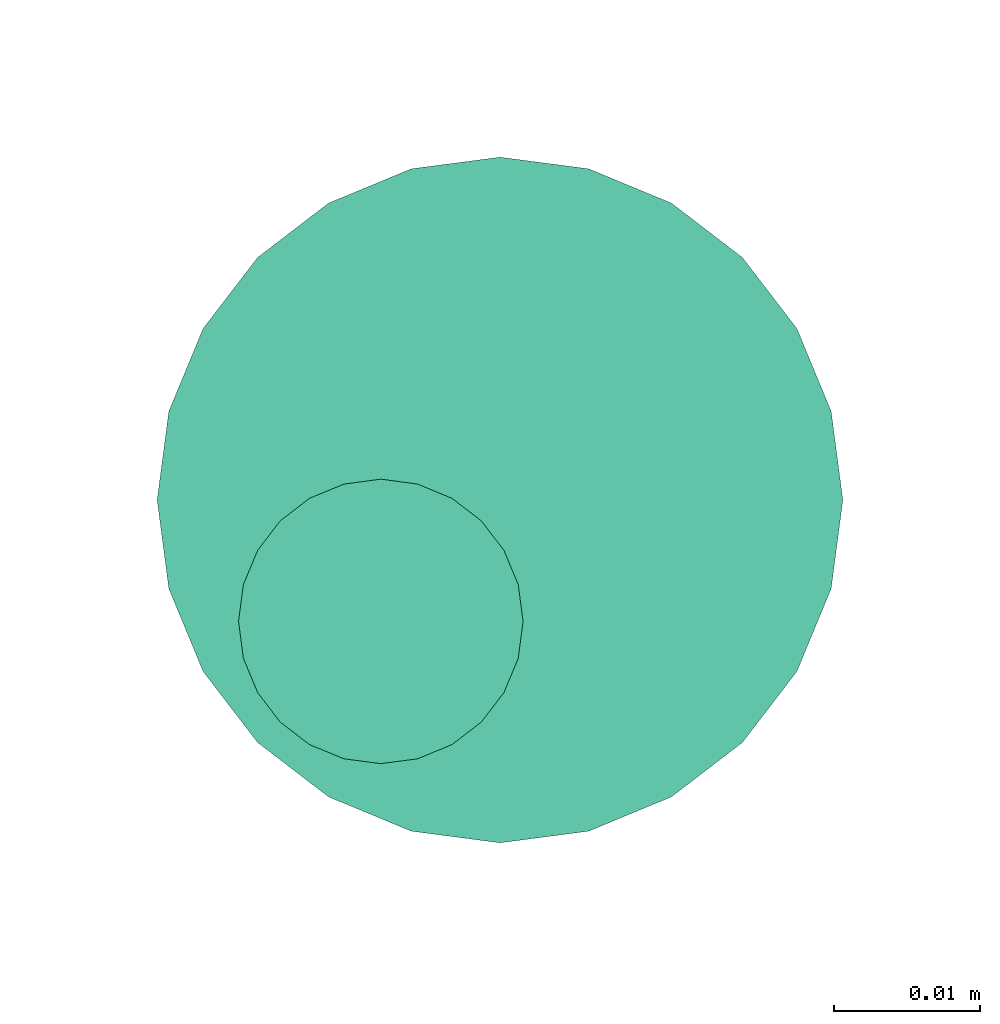
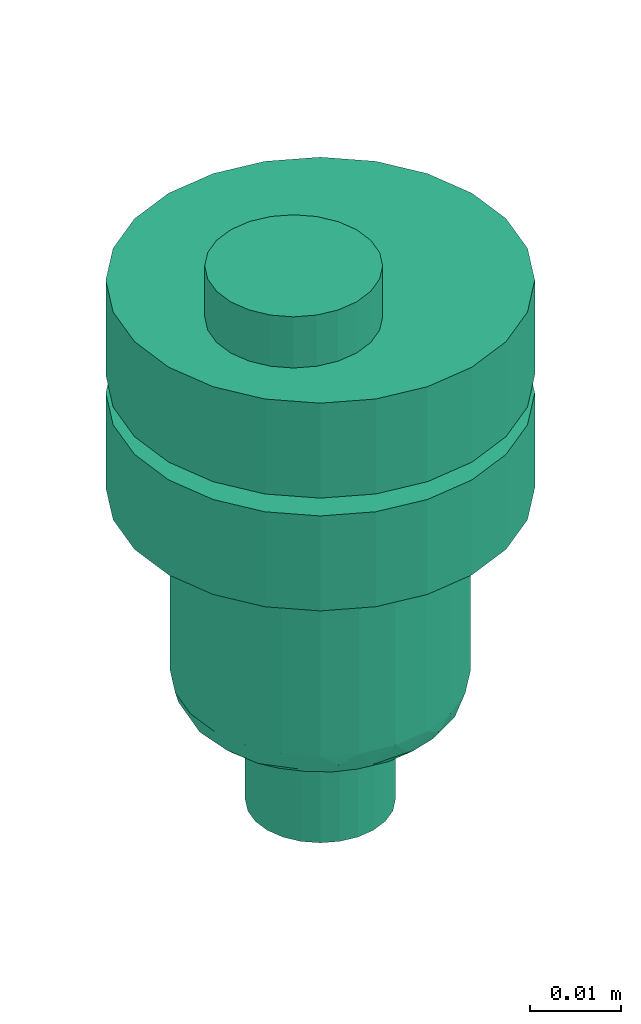
# One storey, part 64 of 93: 1 flow controller.
"""IFC2X3 building model written with IfcOpenShell, lengths in millimetres."""

from ifc_helpers import new_model, entity, si_unit, converted_unit, derived_unit, direction, frame, origin, place, context, subcontext, project, spatial, faceted_brep, source, transform, mapped, material, type_object, type_shapes, element, save


model = new_model("IFC2X3")

# Units and contexts
model_context = context("Model", 3, precision=0.01, world=origin(), true_north=direction((6.12303176911189e-17, 1.0)))
body_context = subcontext(model_context, "Body", "Model", "MODEL_VIEW")
ifc_project = project(units=[si_unit("LENGTHUNIT", "METRE", prefix="MILLI"), si_unit("AREAUNIT", "SQUARE_METRE"), si_unit("VOLUMEUNIT", "CUBIC_METRE"), converted_unit("PLANEANGLEUNIT", "DEGREE", entity("IfcRatioMeasure", 0.0174532925199433), si_unit("PLANEANGLEUNIT", "RADIAN"), dimensions=[0, 0, 0, 0, 0, 0, 0]), si_unit("MASSUNIT", "GRAM", prefix="KILO"), derived_unit("MASSDENSITYUNIT", [(si_unit("MASSUNIT", "GRAM", prefix="KILO"), 1), (si_unit("LENGTHUNIT", "METRE"), -3)]), derived_unit("MOMENTOFINERTIAUNIT", [(si_unit("LENGTHUNIT", "METRE"), 4)]), si_unit("TIMEUNIT", "SECOND"), si_unit("FREQUENCYUNIT", "HERTZ"), si_unit("THERMODYNAMICTEMPERATUREUNIT", "DEGREE_CELSIUS"), derived_unit("THERMALTRANSMITTANCEUNIT", [(si_unit("MASSUNIT", "GRAM", prefix="KILO"), 1), (si_unit("THERMODYNAMICTEMPERATUREUNIT", "KELVIN"), -1), (si_unit("TIMEUNIT", "SECOND"), -3)]), derived_unit("VOLUMETRICFLOWRATEUNIT", [(si_unit("LENGTHUNIT", "METRE"), 3), (si_unit("TIMEUNIT", "SECOND"), -1)]), derived_unit("MASSFLOWRATEUNIT", [(si_unit("MASSUNIT", "GRAM", prefix="KILO"), 1), (si_unit("TIMEUNIT", "SECOND"), -1)]), derived_unit("ROTATIONALFREQUENCYUNIT", [(si_unit("TIMEUNIT", "SECOND"), -1)]), si_unit("ELECTRICCURRENTUNIT", "AMPERE"), si_unit("ELECTRICVOLTAGEUNIT", "VOLT"), si_unit("POWERUNIT", "WATT"), si_unit("FORCEUNIT", "NEWTON", prefix="KILO"), si_unit("ILLUMINANCEUNIT", "LUX"), si_unit("LUMINOUSFLUXUNIT", "LUMEN"), si_unit("LUMINOUSINTENSITYUNIT", "CANDELA"), derived_unit("USERDEFINED", [(si_unit("MASSUNIT", "GRAM", prefix="KILO"), -1), (si_unit("LENGTHUNIT", "METRE"), -2), (si_unit("TIMEUNIT", "SECOND"), 3), (si_unit("LUMINOUSFLUXUNIT", "LUMEN"), 1)]), derived_unit("LINEARVELOCITYUNIT", [(si_unit("LENGTHUNIT", "METRE"), 1), (si_unit("TIMEUNIT", "SECOND"), -1)]), si_unit("PRESSUREUNIT", "PASCAL"), derived_unit("USERDEFINED", [(si_unit("LENGTHUNIT", "METRE"), -2), (si_unit("MASSUNIT", "GRAM", prefix="KILO"), 1), (si_unit("TIMEUNIT", "SECOND"), -2)]), derived_unit("LINEARFORCEUNIT", [(si_unit("MASSUNIT", "GRAM", prefix="KILO"), 1), (si_unit("LENGTHUNIT", "METRE"), 1), (si_unit("TIMEUNIT", "SECOND"), -2), (si_unit("LENGTHUNIT", "METRE"), -1)]), derived_unit("PLANARFORCEUNIT", [(si_unit("MASSUNIT", "GRAM", prefix="KILO"), 1), (si_unit("LENGTHUNIT", "METRE"), 1), (si_unit("TIMEUNIT", "SECOND"), -2), (si_unit("LENGTHUNIT", "METRE"), -2)])], contexts=[model_context])

# Site, building, storey
site_placement = place(None, origin())
site = spatial("IfcSite", under=ifc_project, at=site_placement, CompositionType="ELEMENT")
building_placement = place(site_placement, origin())
building = spatial("IfcBuilding", under=site, at=building_placement, CompositionType="ELEMENT")
storey_placement = place(building_placement, frame((0.0, 0.0, -4200.0)))
storey = spatial("IfcBuildingStorey", under=building, at=storey_placement, CompositionType="ELEMENT", Elevation=-4200.0)

# Flow controller
ifc_material = material()
valve_type = type_object("IfcValveType", PredefinedType="NOTDEFINED", material=ifc_material)
shared_shape = source(origin(), body_context, "Body", "Brep", [
    faceted_brep([(-6.86, -13.27, -15.58), (-5.66, -12.77, -15.58), (-5.66, -12.77, -13.2), (-6.86, -13.27, -13.2), (-6.86, -13.27, -0.5), (-5.66, -12.77, -0.5), (-5.66, -12.77, 2.49), (-6.86, -13.27, 2.49), (-8.16, -13.44, -15.58), (-8.16, -13.44, -13.2), (-8.16, -13.44, -0.5), (-8.16, -13.44, 2.49), (-3.83, -10.94, -15.58), (-3.33, -9.74, -15.58), (-3.33, -9.74, -13.2), (-3.83, -10.94, -13.2), (-3.83, -10.94, -0.5), (-3.33, -9.74, -0.5), (-3.33, -9.74, 2.49), (-3.83, -10.94, 2.49), (-4.62, -11.98, -15.58), (-4.62, -11.98, -13.2), (-4.62, -11.98, -0.5), (-4.62, -11.98, 2.49), (-3.16, -8.44, -13.2), (-3.16, -8.44, -15.58), (-3.16, -8.44, 2.49), (-3.16, -8.44, -0.5), (-3.83, -5.94, -15.58), (-4.62, -4.91, -15.58), (-4.62, -4.91, -13.2), (-3.83, -5.94, -13.2), (-3.83, -5.94, -0.5), (-4.62, -4.91, -0.5), (-4.62, -4.91, 2.49), (-3.83, -5.94, 2.49), (-3.33, -7.15, -15.58), (-3.33, -7.15, -13.2), (-3.33, -7.15, -0.5), (-3.33, -7.15, 2.49), (-6.86, -3.61, -15.58), (-8.16, -3.44, -15.58), (-8.16, -3.44, -13.2), (-6.86, -3.61, -13.2), (-6.86, -3.61, -0.5), (-8.16, -3.44, -0.5), (-8.16, -3.44, 2.49), (-6.86, -3.61, 2.49), (-5.66, -4.11, -15.58), (-5.66, -4.11, -13.2), (-5.66, -4.11, -0.5), (-5.66, -4.11, 2.49), (-9.45, -3.61, -0.5), (-9.45, -3.61, 2.49), (-9.45, -3.61, -15.58), (-9.45, -3.61, -13.2), (-10.66, -4.11, -0.5), (-10.66, -4.11, 2.49), (-10.66, -4.11, -15.58), (-10.66, -4.11, -13.2), (-12.49, -5.94, 2.49), (-11.69, -4.91, 2.49), (-11.69, -4.91, -0.5), (-12.49, -5.94, -0.5), (-11.69, -4.91, -15.58), (-12.49, -5.94, -15.58), (-12.49, -5.94, -13.2), (-11.69, -4.91, -13.2), (-12.99, -7.15, 2.49), (-12.99, -7.15, -0.5), (-12.99, -7.15, -15.58), (-12.99, -7.15, -13.2), (-13.16, -8.44, 2.49), (-13.16, -8.44, -0.5), (-13.16, -8.44, -13.2), (-13.16, -8.44, -15.58), (-12.49, -10.94, -0.5), (-12.49, -10.94, 2.49), (-12.99, -9.74, 2.49), (-12.99, -9.74, -0.5), (-12.99, -9.74, -15.58), (-12.49, -10.94, -15.58), (-12.49, -10.94, -13.2), (-12.99, -9.74, -13.2), (-11.69, -11.98, -0.5), (-11.69, -11.98, 2.49), (-11.69, -11.98, -15.58), (-11.69, -11.98, -13.2), (-9.45, -13.27, 2.49), (-10.66, -12.77, 2.49), (-10.66, -12.77, -0.5), (-9.45, -13.27, -0.5), (-10.66, -12.77, -15.58), (-9.45, -13.27, -15.58), (-9.45, -13.27, -13.2), (-10.66, -12.77, -13.2), (6.08, -22.7, -0.5), (0.0, -23.5, -0.5), (11.75, -20.35, -0.5), (16.62, -16.62, -0.5), (20.35, -11.75, -0.5), (22.7, -6.08, -0.5), (23.5, 0.0, -0.5), (22.7, 6.08, -0.5), (20.35, 11.75, -0.5), (16.62, 16.62, -0.5), (11.75, 20.35, -0.5), (6.08, 22.7, -0.5), (0.0, 23.5, -0.5), (-6.08, 22.7, -0.5), (-11.75, 20.35, -0.5), (-16.62, 16.62, -0.5), (-20.35, 11.75, -0.5), (-22.7, 6.08, -0.5), (-23.5, 0.0, -0.5), (-22.7, -6.08, -0.5), (-20.35, -11.75, -0.5), (-16.62, -16.62, -0.5), (-11.75, -20.35, -0.5), (-6.08, -22.7, -0.5), (11.75, 20.35, -13.2), (6.08, 22.7, -13.2), (16.62, 16.62, -13.2), (20.35, 11.75, -13.2), (22.7, 6.08, -13.2), (23.5, 0.0, -13.2), (22.7, -6.08, -13.2), (20.35, -11.75, -13.2), (16.62, -16.62, -13.2), (11.75, -20.35, -13.2), (6.08, -22.7, -13.2), (0.0, -23.5, -13.2), (-6.08, -22.7, -13.2), (-11.75, -20.35, -13.2), (-16.62, -16.62, -13.2), (-20.35, -11.75, -13.2), (-22.7, -6.08, -13.2), (-23.5, 0.0, -13.2), (-22.7, 6.08, -13.2), (-20.35, 11.75, -13.2), (-16.62, 16.62, -13.2), (-11.75, 20.35, -13.2), (-6.08, 22.7, -13.2), (0.0, 23.5, -13.2), (-22.7, -6.08, -28.28), (-22.7, -6.08, -15.58), (-23.5, 0.0, -15.58), (-23.5, 0.0, -28.28), (-20.35, -11.75, -28.28), (-20.35, -11.75, -15.58), (-11.75, -20.35, -15.58), (-16.62, -16.62, -15.58), (-16.62, -16.62, -28.28), (-11.75, -20.35, -28.28), (-6.08, -22.7, -15.58), (-6.08, -22.7, -28.28), (0.0, -23.5, -15.58), (0.0, -23.5, -28.28), (6.08, -22.7, -28.28), (6.08, -22.7, -15.58), (11.75, -20.35, -28.28), (11.75, -20.35, -15.58), (20.35, -11.75, -15.58), (16.62, -16.62, -15.58), (16.62, -16.62, -28.28), (20.35, -11.75, -28.28), (22.7, -6.08, -15.58), (22.7, -6.08, -28.28), (23.5, 0.0, -15.58), (23.5, 0.0, -28.28), (22.7, 6.08, -28.28), (22.7, 6.08, -15.58), (20.35, 11.75, -28.28), (20.35, 11.75, -15.58), (11.75, 20.35, -15.58), (16.62, 16.62, -15.58), (16.62, 16.62, -28.28), (11.75, 20.35, -28.28), (6.08, 22.7, -15.58), (6.08, 22.7, -28.28), (0.0, 23.5, -15.58), (0.0, 23.5, -28.28), (-6.08, 22.7, -28.28), (-6.08, 22.7, -15.58), (-11.75, 20.35, -28.28), (-11.75, 20.35, -15.58), (-20.35, 11.75, -15.58), (-16.62, 16.62, -15.58), (-16.62, 16.62, -28.28), (-20.35, 11.75, -28.28), (-22.7, 6.08, -15.58), (-22.7, 6.08, -28.28), (8.23, 14.25, -28.28), (4.26, 15.89, -28.28), (11.63, 11.63, -28.28), (14.25, 8.22, -28.28), (15.89, 4.26, -28.28), (16.45, 0.0, -28.28), (15.89, -4.26, -28.28), (14.25, -8.23, -28.28), (11.63, -11.63, -28.28), (8.23, -14.25, -28.28), (4.26, -15.89, -28.28), (0.0, -16.45, -28.28), (-4.26, -15.89, -28.28), (-8.22, -14.25, -28.28), (-11.63, -11.63, -28.28), (-14.25, -8.23, -28.28), (-15.89, -4.26, -28.28), (-16.45, 0.0, -28.28), (-15.89, 4.26, -28.28), (-14.25, 8.22, -28.28), (-11.63, 11.63, -28.28), (-8.22, 14.25, -28.28), (-4.26, 15.89, -28.28), (0.0, 16.45, -28.28), (-15.89, -4.26, -52.7), (-16.45, 0.0, -52.7), (-14.25, -8.23, -52.7), (-11.63, -11.63, -52.7), (-8.22, -14.25, -52.7), (-4.26, -15.89, -52.7), (0.0, -16.45, -52.7), (4.26, -15.89, -52.7), (8.23, -14.25, -52.7), (11.63, -11.63, -52.7), (14.25, -8.23, -52.7), (15.89, -4.26, -52.7), (16.45, 0.0, -52.7), (15.89, 4.26, -52.7), (14.25, 8.22, -52.7), (11.63, 11.63, -52.7), (8.23, 14.25, -52.7), (4.26, 15.89, -52.7), (0.0, 16.45, -52.7), (-4.26, 15.89, -52.7), (-8.22, 14.25, -52.7), (-11.63, 11.63, -52.7), (-14.25, 8.22, -52.7), (-15.89, 4.26, -52.7), (10.61, 9.36, -56.39), (8.29, 11.45, -56.39), (9.98, 12.23, -54.94), (-13.58, 4.48, -56.31), (-14.89, 5.25, -54.94), (-12.77, 8.5, -55.51), (6.32, 14.92, -54.11), (-3.39, 14.2, -56.13), (-6.26, 13.77, -55.71), (-2.15, 15.69, -54.85), (2.15, 15.59, -55.0), (10.54, 4.37, -56.8), (12.15, 6.9, -56.46), (14.89, 5.25, -54.94), (13.8, 0.0, -56.2), (13.58, 4.48, -56.31), (12.77, 8.5, -55.51), (15.25, 0.0, -55.6), (-9.98, 12.23, -54.94), (6.26, 13.77, -55.71), (4.37, 10.54, -56.8), (3.28, 13.85, -56.34), (-15.25, 0.0, -55.6), (-6.32, 14.92, -54.11), (-10.54, 4.37, -56.8), (-12.35, 0.0, -56.8), (-12.15, 6.9, -56.46), (-10.61, 9.36, -56.39), (8.73, 8.73, -56.8), (-4.37, 10.54, -56.8), (-6.55, 9.64, -56.8), (-13.8, 0.0, -56.2), (-0.21, 14.49, -56.2), (0.0, 12.35, -56.8), (-8.73, 8.73, -56.8), (-8.29, 11.45, -56.39), (12.35, 0.0, -56.8), (-10.61, -9.36, -56.39), (-8.29, -11.45, -56.39), (-9.98, -12.23, -54.94), (13.58, -4.48, -56.31), (14.89, -5.25, -54.94), (12.77, -8.5, -55.51), (-6.32, -14.92, -54.11), (6.32, -14.92, -54.11), (9.98, -12.23, -54.94), (-2.15, -15.59, -55.0), (-10.54, -4.37, -56.8), (-12.15, -6.9, -56.46), (-12.77, -8.5, -55.51), (2.15, -15.69, -54.85), (-14.89, -5.25, -54.94), (-13.58, -4.48, -56.31), (-8.73, -8.73, -56.8), (6.26, -13.77, -55.71), (4.37, -10.54, -56.8), (6.55, -9.64, -56.8), (12.15, -6.9, -56.46), (10.61, -9.36, -56.39), (10.54, -4.37, -56.8), (-6.26, -13.77, -55.71), (-4.37, -10.54, -56.8), (-3.28, -13.85, -56.34), (3.39, -14.2, -56.13), (0.21, -14.49, -56.2), (0.0, -12.35, -56.8), (8.73, -8.73, -56.8), (8.29, -11.45, -56.39), (-7.94, 2.13, -56.8), (-8.22, 0.0, -56.8), (-7.12, 4.11, -56.8), (-7.94, -2.13, -56.8), (-7.12, -4.11, -56.8), (-5.82, -5.82, -56.8), (-4.11, -7.12, -56.8), (-2.13, -7.94, -56.8), (0.0, -8.23, -56.8), (2.13, -7.94, -56.8), (4.11, -7.12, -56.8), (5.82, -5.82, -56.8), (7.12, -4.11, -56.8), (7.94, -2.13, -56.8), (8.23, 0.0, -56.8), (7.94, 2.13, -56.8), (7.12, 4.11, -56.8), (5.82, 5.82, -56.8), (4.11, 7.12, -56.8), (2.13, 7.94, -56.8), (0.0, 8.22, -56.8), (-2.13, 7.94, -56.8), (-4.11, 7.12, -56.8), (-5.82, 5.82, -56.8), (0.0, 8.22, -70.0), (2.13, 7.94, -70.0), (4.11, 7.12, -70.0), (5.82, 5.82, -70.0), (7.12, 4.11, -70.0), (7.94, 2.13, -70.0), (8.23, 0.0, -70.0), (7.94, -2.13, -70.0), (7.12, -4.11, -70.0), (5.82, -5.82, -70.0), (4.11, -7.12, -70.0), (2.13, -7.94, -70.0), (0.0, -8.23, -70.0), (-2.13, -7.94, -70.0), (-4.11, -7.12, -70.0), (-5.82, -5.82, -70.0), (-7.12, -4.11, -70.0), (-7.94, -2.13, -70.0), (-8.22, 0.0, -70.0), (-7.94, 2.13, -70.0), (-7.12, 4.11, -70.0), (-5.82, 5.82, -70.0), (-4.11, 7.12, -70.0), (-2.13, 7.94, -70.0), (1.25, -5.8, 9.33), (0.27, -3.45, 9.33), (-1.28, -1.43, 9.33), (-3.3, 0.12, 9.33), (-5.65, 1.09, 9.33), (-8.17, 1.43, 9.33), (-10.69, 1.09, 9.33), (-13.05, 0.12, 9.33), (-15.07, -1.43, 9.33), (-16.61, -3.45, 9.33), (-17.59, -5.8, 9.33), (-17.92, -8.32, 9.33), (-17.59, -10.85, 9.33), (-16.61, -13.2, 9.33), (-15.07, -15.22, 9.33), (-13.05, -16.77, 9.33), (-10.69, -17.74, 9.33), (-8.17, -18.07, 9.33), (-5.65, -17.74, 9.33), (-3.3, -16.77, 9.33), (-1.28, -15.22, 9.33), (0.27, -13.2, 9.33), (1.25, -10.85, 9.33), (1.58, -8.32, 9.33), (-16.61, -3.45, 2.49), (-17.59, -5.8, 2.49), (-15.07, -1.43, 2.49), (-13.05, 0.12, 2.49), (-10.69, 1.09, 2.49), (-8.17, 1.43, 2.49), (-5.65, 1.09, 2.49), (-3.3, 0.12, 2.49), (-1.28, -1.43, 2.49), (0.27, -3.45, 2.49), (1.25, -5.8, 2.49), (1.58, -8.32, 2.49), (1.25, -10.85, 2.49), (0.27, -13.2, 2.49), (-1.28, -15.22, 2.49), (-3.3, -16.77, 2.49), (-5.65, -17.74, 2.49), (-8.17, -18.07, 2.49), (-10.69, -17.74, 2.49), (-13.05, -16.77, 2.49), (-15.07, -15.22, 2.49), (-16.61, -13.2, 2.49), (-17.59, -10.85, 2.49), (-17.92, -8.32, 2.49)], [[[0, 1, 2, 3]], [[4, 5, 6, 7]], [[8, 0, 3, 9]], [[10, 4, 7, 11]], [[12, 13, 14, 15]], [[16, 17, 18, 19]], [[20, 12, 15, 21]], [[22, 16, 19, 23]], [[1, 20, 21, 2]], [[5, 22, 23, 6]], [[24, 14, 13, 25]], [[26, 18, 17, 27]], [[28, 29, 30, 31]], [[32, 33, 34, 35]], [[36, 28, 31, 37]], [[38, 32, 35, 39]], [[40, 41, 42, 43]], [[44, 45, 46, 47]], [[48, 40, 43, 49]], [[50, 44, 47, 51]], [[29, 48, 49, 30]], [[33, 50, 51, 34]], [[36, 37, 24, 25]], [[38, 39, 26, 27]], [[52, 53, 46, 45]], [[41, 54, 55, 42]], [[56, 57, 53, 52]], [[54, 58, 59, 55]], [[60, 61, 62, 63]], [[64, 65, 66, 67]], [[56, 62, 61, 57]], [[58, 64, 67, 59]], [[68, 60, 63, 69]], [[65, 70, 71, 66]], [[72, 68, 69, 73]], [[74, 71, 70, 75]], [[76, 77, 78, 79]], [[80, 81, 82, 83]], [[84, 85, 77, 76]], [[81, 86, 87, 82]], [[88, 89, 90, 91]], [[92, 93, 94, 95]], [[84, 90, 89, 85]], [[86, 92, 95, 87]], [[11, 88, 91, 10]], [[93, 8, 9, 94]], [[79, 78, 72, 73]], [[80, 83, 74, 75]], [[96, 16, 97]], [[16, 96, 17]], [[98, 17, 96]], [[27, 17, 98]], [[98, 99, 27]], [[100, 27, 99]], [[100, 38, 27]], [[38, 100, 101]], [[38, 101, 102]], [[38, 102, 32]], [[32, 102, 103]], [[104, 32, 103]], [[104, 33, 32]], [[104, 105, 33]], [[105, 106, 33]], [[106, 50, 33]], [[50, 106, 107]], [[50, 107, 108]], [[108, 44, 50]], [[44, 108, 109]], [[44, 109, 110]], [[110, 45, 44]], [[45, 110, 111]], [[45, 111, 112]], [[52, 45, 112]], [[52, 112, 113]], [[56, 52, 113]], [[113, 114, 56]], [[114, 62, 56]], [[62, 114, 63]], [[114, 115, 63]], [[115, 69, 63]], [[73, 69, 115]], [[115, 116, 73]], [[116, 79, 73]], [[79, 116, 76]], [[76, 116, 117]], [[76, 117, 84]], [[117, 90, 84]], [[118, 90, 117]], [[90, 118, 91]], [[10, 91, 118]], [[10, 118, 119]], [[97, 5, 119]], [[119, 5, 4]], [[10, 119, 4]], [[22, 97, 16]], [[22, 5, 97]], [[120, 49, 121]], [[49, 120, 30]], [[122, 30, 120]], [[122, 123, 30]], [[30, 123, 31]], [[123, 124, 31]], [[31, 124, 125]], [[37, 31, 125]], [[37, 125, 126]], [[127, 37, 126]], [[37, 127, 24]], [[127, 128, 24]], [[129, 24, 128]], [[14, 24, 129]], [[129, 130, 14]], [[130, 15, 14]], [[130, 131, 15]], [[131, 21, 15]], [[2, 21, 131]], [[2, 131, 132]], [[2, 132, 3]], [[3, 132, 9]], [[132, 133, 9]], [[94, 9, 133]], [[133, 95, 94]], [[95, 133, 134]], [[95, 134, 87]], [[82, 87, 134]], [[135, 82, 134]], [[135, 83, 82]], [[74, 83, 135]], [[135, 136, 74]], [[74, 136, 71]], [[71, 136, 66]], [[66, 136, 137]], [[137, 67, 66]], [[67, 137, 59]], [[137, 138, 59]], [[59, 138, 55]], [[139, 55, 138]], [[55, 139, 42]], [[140, 42, 139]], [[141, 42, 140]], [[42, 141, 43]], [[141, 142, 43]], [[43, 142, 143]], [[121, 49, 143]], [[43, 143, 49]], [[136, 115, 114, 137]], [[144, 145, 146, 147]], [[135, 116, 115, 136]], [[148, 149, 145, 144]], [[118, 117, 134, 133]], [[150, 151, 152, 153]], [[135, 134, 117, 116]], [[148, 152, 151, 149]], [[119, 118, 133, 132]], [[154, 150, 153, 155]], [[97, 119, 132, 131]], [[156, 154, 155, 157]], [[130, 96, 97, 131]], [[158, 159, 156, 157]], [[129, 98, 96, 130]], [[160, 161, 159, 158]], [[100, 99, 128, 127]], [[162, 163, 164, 165]], [[129, 128, 99, 98]], [[160, 164, 163, 161]], [[101, 100, 127, 126]], [[166, 162, 165, 167]], [[102, 101, 126, 125]], [[168, 166, 167, 169]], [[124, 103, 102, 125]], [[170, 171, 168, 169]], [[123, 104, 103, 124]], [[172, 173, 171, 170]], [[106, 105, 122, 120]], [[174, 175, 176, 177]], [[123, 122, 105, 104]], [[172, 176, 175, 173]], [[107, 106, 120, 121]], [[178, 174, 177, 179]], [[108, 107, 121, 143]], [[180, 178, 179, 181]], [[142, 109, 108, 143]], [[182, 183, 180, 181]], [[141, 110, 109, 142]], [[184, 185, 183, 182]], [[112, 111, 140, 139]], [[186, 187, 188, 189]], [[141, 140, 111, 110]], [[184, 188, 187, 185]], [[113, 112, 139, 138]], [[190, 186, 189, 191]], [[114, 113, 138, 137]], [[146, 190, 191, 147]], [[159, 12, 156]], [[12, 159, 13]], [[161, 13, 159]], [[25, 13, 161]], [[161, 163, 25]], [[162, 25, 163]], [[162, 36, 25]], [[36, 162, 166]], [[36, 166, 168]], [[36, 168, 28]], [[28, 168, 171]], [[173, 28, 171]], [[173, 29, 28]], [[173, 175, 29]], [[175, 174, 29]], [[174, 48, 29]], [[48, 174, 178]], [[48, 178, 180]], [[180, 40, 48]], [[40, 180, 183]], [[40, 183, 185]], [[185, 41, 40]], [[41, 185, 187]], [[41, 187, 186]], [[54, 41, 186]], [[54, 186, 190]], [[58, 54, 190]], [[190, 146, 58]], [[146, 64, 58]], [[64, 146, 65]], [[146, 145, 65]], [[145, 70, 65]], [[75, 70, 145]], [[145, 149, 75]], [[149, 80, 75]], [[80, 149, 81]], [[81, 149, 151]], [[81, 151, 86]], [[151, 92, 86]], [[150, 92, 151]], [[92, 150, 93]], [[8, 93, 150]], [[8, 150, 154]], [[156, 1, 154]], [[154, 1, 0]], [[8, 154, 0]], [[20, 156, 12]], [[20, 1, 156]], [[177, 176, 192]], [[177, 192, 193]], [[193, 179, 177]], [[192, 176, 194]], [[172, 194, 176]], [[195, 194, 172]], [[196, 195, 172]], [[196, 172, 170]], [[196, 170, 197]], [[197, 170, 169]], [[198, 197, 169]], [[198, 169, 167]], [[199, 198, 167]], [[199, 167, 165]], [[200, 199, 165]], [[165, 164, 200]], [[164, 201, 200]], [[201, 164, 160]], [[201, 160, 202]], [[158, 202, 160]], [[202, 158, 203]], [[203, 158, 157]], [[157, 204, 203]], [[204, 157, 155]], [[204, 155, 205]], [[153, 205, 155]], [[153, 206, 205]], [[153, 152, 206]], [[207, 206, 152]], [[148, 207, 152]], [[144, 207, 148]], [[208, 207, 144]], [[208, 144, 147]], [[147, 209, 208]], [[191, 209, 147]], [[191, 210, 209]], [[210, 191, 189]], [[211, 210, 189]], [[211, 189, 188]], [[211, 188, 212]], [[188, 184, 212]], [[212, 184, 213]], [[213, 184, 182]], [[182, 214, 213]], [[181, 214, 182]], [[179, 215, 181]], [[214, 181, 215]], [[179, 193, 215]], [[216, 208, 209, 217]], [[218, 207, 208, 216]], [[205, 206, 219, 220]], [[218, 219, 206, 207]], [[204, 205, 220, 221]], [[221, 222, 203, 204]], [[202, 223, 224, 201]], [[225, 200, 201, 224]], [[199, 226, 227, 198]], [[225, 226, 199, 200]], [[198, 227, 228, 197]], [[223, 202, 203, 222]], [[229, 196, 197, 228]], [[230, 195, 196, 229]], [[192, 194, 231, 232]], [[230, 231, 194, 195]], [[193, 192, 232, 233]], [[193, 233, 234, 215]], [[214, 235, 236, 213]], [[237, 212, 213, 236]], [[211, 238, 239, 210]], [[237, 238, 211, 212]], [[210, 239, 217, 209]], [[235, 214, 215, 234]], [[240, 241, 242]], [[243, 244, 245]], [[246, 233, 232]], [[247, 248, 249]], [[233, 246, 250]], [[251, 240, 252]], [[253, 254, 255]], [[231, 256, 242]], [[229, 257, 253]], [[228, 257, 229]], [[230, 253, 256]], [[253, 255, 256]], [[229, 253, 230]], [[236, 258, 237]], [[242, 232, 231]], [[259, 260, 261]], [[249, 234, 250]], [[262, 239, 244]], [[230, 256, 231]], [[235, 263, 236]], [[244, 239, 238]], [[243, 264, 265]], [[263, 258, 236]], [[241, 260, 259]], [[234, 249, 235]], [[245, 244, 238]], [[233, 250, 234]], [[258, 245, 237]], [[266, 267, 264]], [[238, 237, 245]], [[240, 251, 268]], [[248, 269, 270]], [[262, 217, 239]], [[243, 271, 244]], [[246, 242, 259]], [[258, 267, 245]], [[240, 256, 252]], [[240, 242, 256]], [[247, 249, 272]], [[263, 249, 248]], [[273, 272, 261]], [[272, 249, 250]], [[274, 267, 275]], [[270, 274, 275]], [[241, 240, 268]], [[275, 258, 248]], [[264, 267, 274]], [[261, 272, 250]], [[247, 273, 269]], [[259, 261, 250]], [[273, 261, 260]], [[273, 247, 272]], [[269, 248, 247]], [[266, 245, 267]], [[251, 255, 276]], [[254, 253, 257]], [[254, 276, 255]], [[271, 262, 244]], [[243, 265, 271]], [[260, 241, 268]], [[242, 241, 259]], [[258, 275, 267]], [[270, 275, 248]], [[242, 246, 232]], [[250, 246, 259]], [[249, 263, 235]], [[258, 263, 248]], [[256, 255, 252]], [[255, 251, 252]], [[264, 243, 266]], [[243, 245, 266]], [[277, 278, 279]], [[280, 281, 282]], [[283, 221, 220]], [[284, 285, 224]], [[221, 283, 286]], [[287, 277, 288]], [[277, 289, 288]], [[219, 289, 279]], [[290, 222, 286]], [[217, 262, 216]], [[218, 291, 289]], [[291, 292, 289]], [[277, 287, 293]], [[216, 291, 218]], [[279, 220, 219]], [[294, 295, 296]], [[224, 285, 225]], [[257, 227, 281]], [[297, 298, 299]], [[226, 281, 227]], [[226, 225, 282]], [[291, 271, 292]], [[227, 257, 228]], [[226, 282, 281]], [[277, 279, 289]], [[218, 289, 219]], [[300, 301, 302]], [[290, 223, 222]], [[280, 254, 281]], [[223, 284, 224]], [[285, 282, 225]], [[221, 286, 222]], [[278, 301, 300]], [[303, 294, 290]], [[216, 262, 291]], [[285, 298, 282]], [[283, 279, 300]], [[280, 299, 276]], [[303, 290, 304]], [[284, 290, 294]], [[305, 304, 302]], [[304, 290, 286]], [[306, 298, 307]], [[296, 306, 307]], [[278, 277, 293]], [[307, 285, 294]], [[299, 298, 306]], [[302, 304, 286]], [[303, 305, 295]], [[300, 302, 286]], [[305, 302, 301]], [[305, 303, 304]], [[295, 294, 303]], [[297, 282, 298]], [[287, 292, 265]], [[271, 291, 262]], [[271, 265, 292]], [[254, 257, 281]], [[280, 276, 254]], [[301, 278, 293]], [[279, 278, 300]], [[285, 307, 298]], [[296, 307, 294]], [[279, 283, 220]], [[286, 283, 300]], [[290, 284, 223]], [[285, 284, 294]], [[289, 292, 288]], [[292, 287, 288]], [[299, 280, 297]], [[280, 282, 297]], [[308, 309, 265]], [[308, 265, 264]], [[308, 264, 274]], [[310, 308, 274]], [[311, 265, 309]], [[311, 287, 265]], [[311, 293, 287]], [[312, 293, 311]], [[312, 313, 293]], [[313, 314, 293]], [[314, 301, 293]], [[314, 305, 301]], [[305, 314, 315]], [[315, 316, 305]], [[316, 317, 305]], [[318, 305, 317]], [[318, 295, 305]], [[318, 296, 295]], [[318, 306, 296]], [[319, 306, 318]], [[320, 306, 319]], [[306, 320, 321]], [[321, 299, 306]], [[321, 276, 299]], [[322, 276, 321]], [[323, 276, 322]], [[323, 251, 276]], [[323, 268, 251]], [[323, 324, 268]], [[324, 325, 268]], [[268, 325, 326]], [[326, 260, 268]], [[326, 273, 260]], [[326, 327, 273]], [[328, 273, 327]], [[328, 329, 273]], [[329, 330, 273]], [[330, 331, 274]], [[330, 274, 270]], [[330, 270, 269]], [[330, 269, 273]], [[310, 274, 331]], [[332, 333, 334, 335, 336, 337, 338, 339, 340, 341, 342, 343, 344, 345, 346, 347, 348, 349, 350, 351, 352, 353, 354, 355]], [[349, 311, 309, 350]], [[348, 312, 311, 349]], [[314, 313, 347, 346]], [[348, 347, 313, 312]], [[315, 314, 346, 345]], [[316, 315, 345, 344]], [[343, 317, 316, 344]], [[342, 318, 317, 343]], [[320, 319, 341, 340]], [[342, 341, 319, 318]], [[321, 320, 340, 339]], [[322, 321, 339, 338]], [[337, 323, 322, 338]], [[336, 324, 323, 337]], [[326, 325, 335, 334]], [[336, 335, 325, 324]], [[327, 326, 334, 333]], [[328, 327, 333, 332]], [[355, 329, 328, 332]], [[354, 330, 329, 355]], [[310, 331, 353, 352]], [[354, 353, 331, 330]], [[308, 310, 352, 351]], [[309, 308, 351, 350]], [[356, 357, 358, 359, 360, 361, 362, 363, 364, 365, 366, 367, 368, 369, 370, 371, 372, 373, 374, 375, 376, 377, 378, 379]], [[380, 60, 381]], [[60, 380, 61]], [[382, 61, 380]], [[61, 382, 57]], [[382, 383, 57]], [[53, 57, 383]], [[384, 53, 383]], [[53, 384, 46]], [[46, 384, 385]], [[386, 46, 385]], [[46, 386, 47]], [[386, 387, 47]], [[51, 47, 387]], [[388, 51, 387]], [[388, 34, 51]], [[388, 389, 34]], [[389, 35, 34]], [[389, 390, 35]], [[39, 35, 390]], [[39, 390, 391]], [[39, 391, 26]], [[392, 26, 391]], [[18, 26, 392]], [[18, 392, 393]], [[19, 18, 393]], [[19, 393, 394]], [[23, 19, 394]], [[394, 395, 23]], [[395, 6, 23]], [[396, 6, 395]], [[396, 7, 6]], [[7, 396, 397]], [[7, 397, 11]], [[11, 397, 88]], [[398, 88, 397]], [[88, 398, 89]], [[89, 398, 399]], [[89, 399, 85]], [[399, 400, 85]], [[85, 400, 77]], [[401, 77, 400]], [[77, 401, 78]], [[402, 78, 401]], [[402, 72, 78]], [[72, 402, 403]], [[403, 381, 68]], [[403, 68, 72]], [[60, 68, 381]], [[396, 374, 373, 397]], [[395, 375, 374, 396]], [[377, 376, 394, 393]], [[395, 394, 376, 375]], [[378, 377, 393, 392]], [[379, 378, 392, 391]], [[390, 356, 379, 391]], [[389, 357, 356, 390]], [[359, 358, 388, 387]], [[389, 388, 358, 357]], [[360, 359, 387, 386]], [[361, 360, 386, 385]], [[384, 362, 361, 385]], [[383, 363, 362, 384]], [[365, 364, 382, 380]], [[383, 382, 364, 363]], [[366, 365, 380, 381]], [[367, 366, 381, 403]], [[402, 368, 367, 403]], [[401, 369, 368, 402]], [[371, 370, 400, 399]], [[401, 400, 370, 369]], [[372, 371, 399, 398]], [[373, 372, 398, 397]]]),
])
type_shapes(valve_type, [shared_shape])
flow_controller_placement = place(storey_placement, frame((15997.26, 14232.02, 35424.86)))
element("IfcFlowController", 1, at=flow_controller_placement, inside=storey, type_object=valve_type, material=ifc_material, context=body_context, shape_type="MappedRepresentation", body=[
    mapped(shared_shape, transform((0.0, 0.0, 0.0), scale=1.0)),
])

save(model, "model.ifc")
